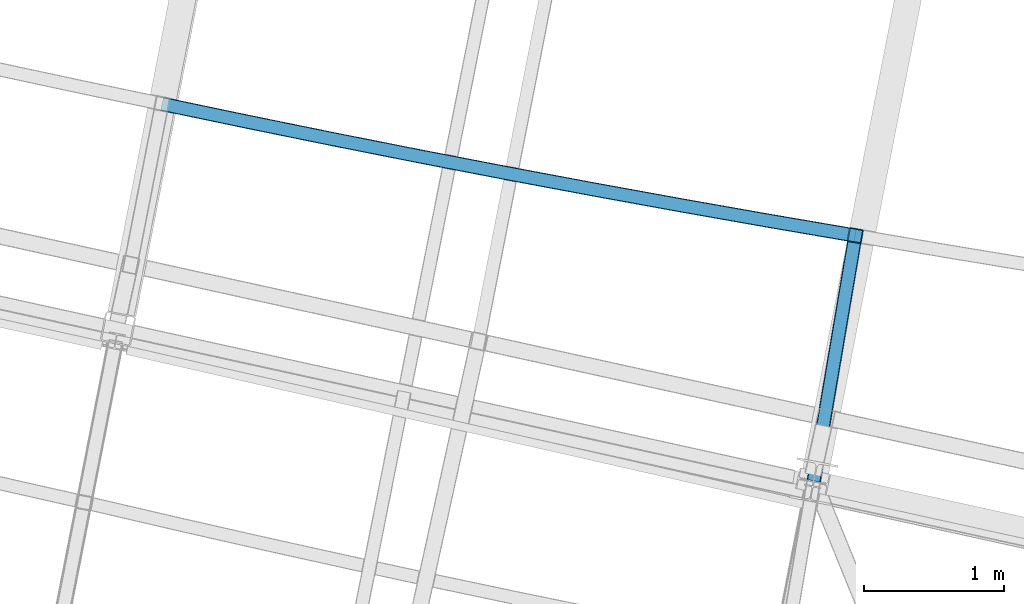
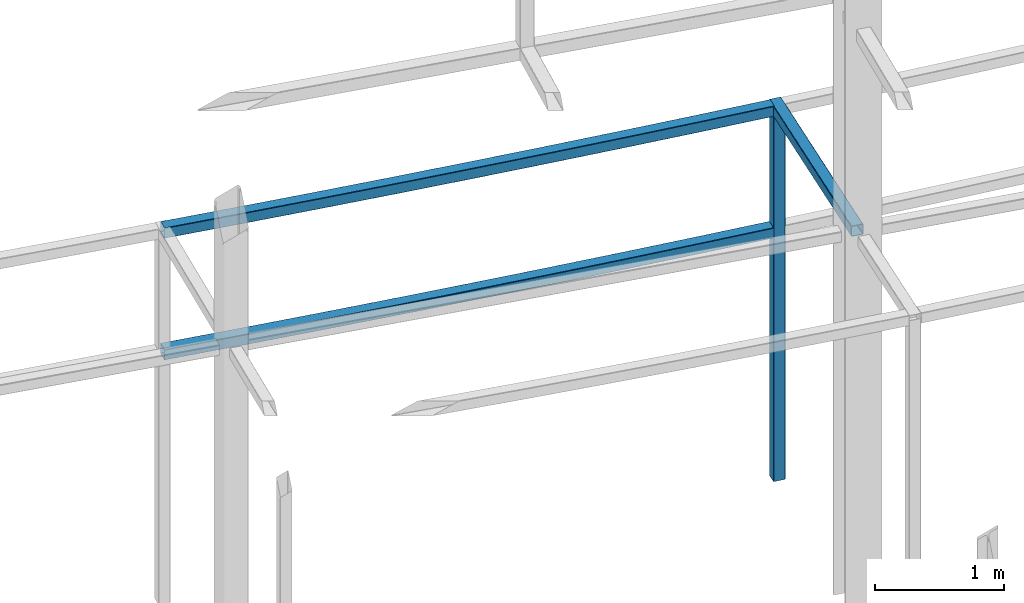
# One storey, part 31 of 215: 4 beams, 4 elements without a shape of their own.
"""IFC2X3 building model written with IfcOpenShell, lengths in millimetres."""

from ifc_helpers import new_model, entity, si_unit, frame, origin_with_axes, origin_2d_with_axis, place, context, subcontext, project, spatial, hollow_rectangle, extrude, clip, halfspace, material, type_object, element, aggregate, save


model = new_model("IFC2X3")

# Units and contexts
model_context = context("Model", 3, precision=1e-05, world=origin_with_axes())
body_context = subcontext(model_context, "Body", "Model", "MODEL_VIEW")
ifc_project = project(units=[si_unit("LENGTHUNIT", "METRE", prefix="MILLI"), si_unit("AREAUNIT", "SQUARE_METRE"), si_unit("VOLUMEUNIT", "CUBIC_METRE"), si_unit("MASSUNIT", "GRAM", prefix="KILO"), si_unit("TIMEUNIT", "SECOND"), si_unit("PLANEANGLEUNIT", "RADIAN"), si_unit("SOLIDANGLEUNIT", "STERADIAN"), si_unit("THERMODYNAMICTEMPERATUREUNIT", "DEGREE_CELSIUS"), si_unit("LUMINOUSINTENSITYUNIT", "LUMEN")], contexts=[model_context])

# Site, building, storey
site_placement = place(None, origin_with_axes())
site = spatial("IfcSite", under=ifc_project, at=site_placement, CompositionType="ELEMENT")
building_placement = place(site_placement, origin_with_axes())
building = spatial("IfcBuilding", under=site, at=building_placement, Name="Undefined", CompositionType="ELEMENT")
storey_placement = place(building_placement, origin_with_axes())
storey = spatial("IfcBuildingStorey", under=building, at=storey_placement, Name="Undefined", CompositionType="ELEMENT", Elevation=0.0)

# Assembly, beam
assembly_1_placement = place(storey_placement, origin_with_axes())
assembly_1 = element("IfcElementAssembly", 1, at=assembly_1_placement, inside=storey, Name="Steel Assembly", AssemblyPlace="NOTDEFINED", PredefinedType="RIGID_FRAME")
ifc_material = material(Name="STEEL/S275JR")
beam_type = type_object("IfcBeamType", PredefinedType="NOTDEFINED")
beam_1_placement = place(assembly_1_placement, frame((60271.4405994586, 8523.54938104012, 5610.00000147687), z_axis=(0.18659974401687, 0.982436021088823, 0.0), x_axis=(0.982436021088823, -0.186599744016871, 0.0)))
beam_1 = element("IfcBeam", 2, at=beam_1_placement, type_object=beam_type, material=ifc_material, Name="POUTRE", context=body_context, shape_type="SweptSolid", body=[
    entity("IfcRevolvedAreaSolid", entity("IfcRectangleHollowProfileDef", "AREA", None, entity("IfcAxis2Placement2D", entity("IfcCartesianPoint", [0.0, 0.0]), entity("IfcDirection", [1.0, 0.0])), 100.0, 100.0, 4.0, 4.0, 8.0), entity("IfcAxis2Placement3D", entity("IfcCartesianPoint", [5042.00108658282, -9.09494701772928e-13, -3.91786609191718e-12]), entity("IfcDirection", [-0.999779300516033, 0.0, -0.0210083378607617]), entity("IfcDirection", [-6.93889390390723e-18, -1.0, -3.46944695195361e-18])), entity("IfcAxis1Placement", entity("IfcCartesianPoint", [0.0, 120000.0, 0.0]), entity("IfcDirection", [-1.0, 0.0, 0.0])), 0.0420197670139758),
])
aggregate(assembly_1, [beam_1])

assembly_2_placement = place(storey_placement, origin_with_axes())
assembly_2 = element("IfcElementAssembly", 3, at=assembly_2_placement, inside=storey, Name="Steel Assembly", AssemblyPlace="NOTDEFINED", PredefinedType="RIGID_FRAME")
beam_2_placement = place(assembly_2_placement, frame((60271.4405993275, 8523.54938102367, 6760.00000147687), z_axis=(0.18659974401687, 0.982436021088823, 0.0), x_axis=(0.982436021088823, -0.186599744016871, 0.0)))
beam_2 = element("IfcBeam", 4, at=beam_2_placement, type_object=beam_type, material=ifc_material, Name="POUTRE", context=body_context, shape_type="SweptSolid", body=[
    entity("IfcRevolvedAreaSolid", entity("IfcRectangleHollowProfileDef", "AREA", None, entity("IfcAxis2Placement2D", entity("IfcCartesianPoint", [0.0, 0.0]), entity("IfcDirection", [1.0, 0.0])), 100.0, 100.0, 4.0, 4.0, 8.0), entity("IfcAxis2Placement3D", entity("IfcCartesianPoint", [5042.00108658282, -9.09494701772928e-13, -3.91786609191718e-12]), entity("IfcDirection", [-0.999779300516033, 0.0, -0.0210083378607617]), entity("IfcDirection", [-6.93889390390723e-18, -1.0, -3.46944695195361e-18])), entity("IfcAxis1Placement", entity("IfcCartesianPoint", [0.0, 120000.0, 0.0]), entity("IfcDirection", [-1.0, 0.0, 0.0])), 0.0420197670134076),
])
aggregate(assembly_2, [beam_2])

assembly_3_placement = place(storey_placement, origin_with_axes())
assembly_3 = element("IfcElementAssembly", 5, at=assembly_3_placement, inside=storey, Name="Steel Assembly", AssemblyPlace="NOTDEFINED", PredefinedType="RIGID_FRAME")
beam_3_placement = place(assembly_3_placement, frame((65224.8840850918, 7582.71326812223, 6760.00000147687), z_axis=(-0.985956528905144, 0.167002164983933, 0.0), x_axis=(0.0, 0.0, -1.0)))
beam_3 = element("IfcBeam", 6, at=beam_3_placement, type_object=beam_type, material=ifc_material, Name="MONTANT", context=body_context, shape_type="SweptSolid", body=[
    extrude(hollow_rectangle(XDim=100.0, YDim=100.0, WallThickness=4.0, InnerFilletRadius=4.0, OuterFilletRadius=8.0, at=origin_2d_with_axis()), frame((3499.99999998675, 0.0, 0.0), z_axis=(-1.0, 0.0, 0.0), x_axis=(-6.93889390390723e-18, -1.0, -3.46944695195361e-18)), (0.0, 0.0, 1.0), 3500.0),
])
aggregate(assembly_3, [beam_3])

assembly_4_placement = place(storey_placement, origin_with_axes())
assembly_4 = element("IfcElementAssembly", 7, at=assembly_4_placement, inside=storey, Name="Steel Assembly", AssemblyPlace="NOTDEFINED", PredefinedType="RIGID_FRAME")
beam_4_placement = place(assembly_4_placement, frame((64960.6652059345, 6022.80565517377, 6760.00000147687), z_axis=(-0.985956528905144, 0.167002164983933, 0.0), x_axis=(0.16700243291904, 0.985956483522027, 0.0)))
beam_4 = element("IfcBeam", 8, at=beam_4_placement, type_object=beam_type, material=ifc_material, Name="POUTRE", context=body_context, shape_type="Clipping", body=[
    clip(extrude(hollow_rectangle(XDim=100.0, YDim=100.0, WallThickness=4.0, InnerFilletRadius=4.0, OuterFilletRadius=8.0, at=origin_2d_with_axis()), frame((1632.1262204047, 9.09494701772928e-13, 0.0), z_axis=(-1.0, 0.0, 0.0), x_axis=(-6.93889390390723e-18, -1.0, -3.46944695195361e-18)), (0.0, 0.0, 1.0), 1862.3), halfspace(frame((-197.648250319151, -49.9999999999991, -75.1628798516176), z_axis=(0.999680784343529, 0.0, -0.025265181857768), x_axis=(-6.93889390390723e-18, -1.0, -3.46944695195361e-18)), True)),
])
aggregate(assembly_4, [beam_4])

save(model, "model.ifc")
